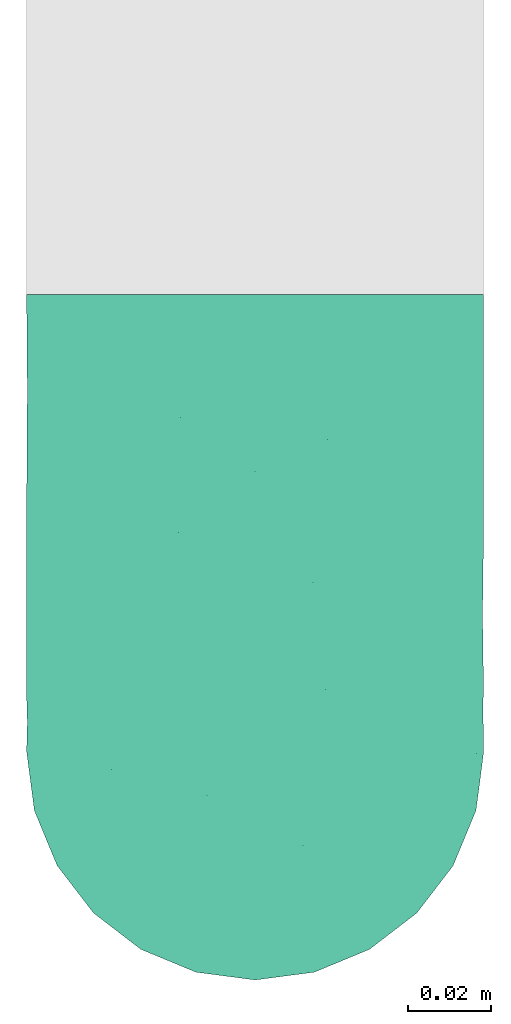
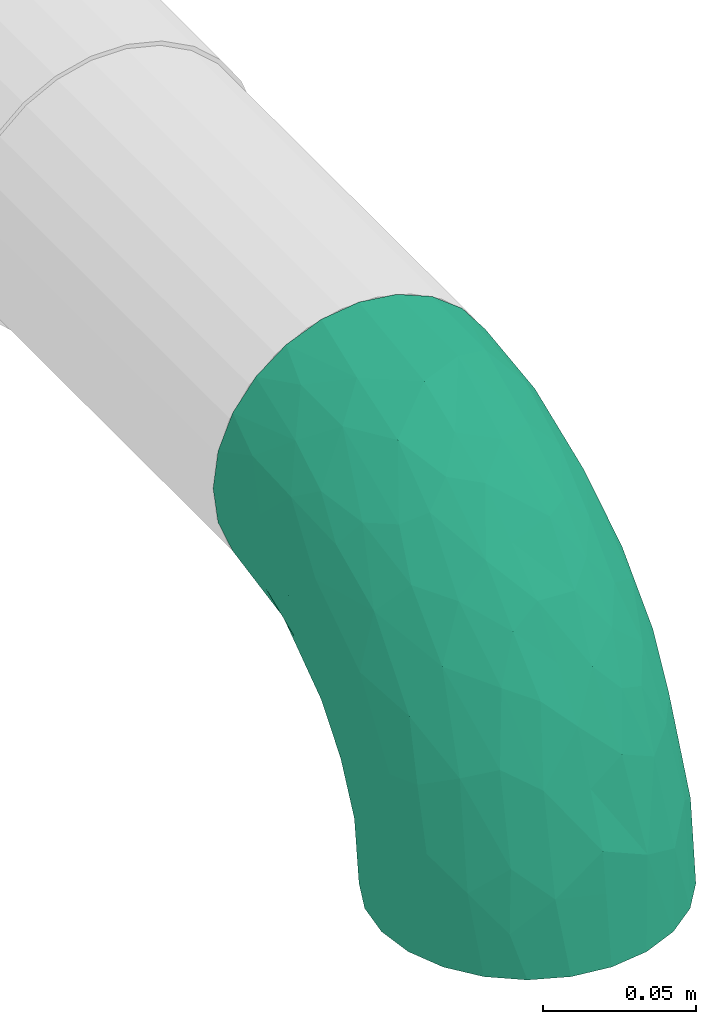
# One storey, part 2 of 2: 1 flow fitting.
"""IFC2X3 building model written with IfcOpenShell, lengths in millimetres."""

import ifcopenshell
import ifcopenshell.guid

model = None  # the IFC model being written
_history = None  # IfcOwnerHistory: only IFC2X3 demands one
_inside = {}  # id of a spatial element -> (the spatial element, [elements in it])
_under = {}  # id of a project, library or spatial element -> (it, [spatial elements below it])
_declared = {}  # id of a project -> (the project, [libraries it declares])
_typed = {}  # id of a type object -> (the type object, [elements of that type])
_made_of = {}  # id of a material, layer set ... -> (it, [elements and type objects made of it])


def new_model(schema):
    """Start an empty IFC model of exactly this schema.

    Asked for "IFC4X3", IfcOpenShell would pick the latest addendum, in which some entities
    have other attributes; the version numbers below select the first issue.
    IFC2X3 requires an IfcOwnerHistory on every rooted entity: one is made here for all.
    """
    global model, _history
    if schema == "IFC4X3":
        model = ifcopenshell.file(schema_version=(4, 3, 0, 0))
    else:
        model = ifcopenshell.file(schema=schema)
    _inside.clear()
    _under.clear()
    _declared.clear()
    _typed.clear()
    _made_of.clear()
    _history = None
    if model.schema == "IFC2X3":
        org = make("IfcOrganization", Name="unknown")
        user = make(
            "IfcPersonAndOrganization",
            ThePerson=make("IfcPerson", FamilyName="unknown"),
            TheOrganization=org,
        )
        app = make(
            "IfcApplication",
            ApplicationDeveloper=org,
            Version="unknown",
            ApplicationFullName="unknown",
            ApplicationIdentifier="unknown",
        )
        _history = make(
            "IfcOwnerHistory",
            OwningUser=user,
            OwningApplication=app,
            ChangeAction="ADDED",
            CreationDate=0,
        )
    return model


def make(cls, **values):
    """One entity of the class cls with the attributes given. An attribute that is None is left unset."""
    return model.create_entity(
        cls, **{name: value for name, value in values.items() if value is not None}
    )


def entity(cls, *values):
    """Any entity or typed value of the class cls, its attributes in the order of the schema. None: left unset."""
    e = model.create_entity(cls)
    for i, value in enumerate(values):
        if value is not None:
            e[i] = value
    return e


def rooted(cls, **values):
    """An entity with a GlobalId (a new one), such as an element, a storey or a relation."""
    return make(cls, GlobalId=ifcopenshell.guid.new(), OwnerHistory=_history, **values)


def si_unit(unit_type, name, prefix=None):
    """IfcSIUnit, for example si_unit("LENGTHUNIT", "METRE", prefix="MILLI")."""
    return make("IfcSIUnit", UnitType=unit_type, Prefix=prefix, Name=name)


def converted_unit(unit_type, name, factor, base, dimensions=None, offset=None):
    """IfcConversionBasedUnit, such as the inch: factor (a typed value) times the base unit."""
    return make(
        "IfcConversionBasedUnit"
        if offset is None
        else "IfcConversionBasedUnitWithOffset",
        ConversionOffset=offset,
        Dimensions=None
        if dimensions is None
        else entity("IfcDimensionalExponents", *dimensions),
        UnitType=unit_type,
        Name=name,
        ConversionFactor=make(
            "IfcMeasureWithUnit", ValueComponent=factor, UnitComponent=base
        ),
    )


def derived_unit(unit_type, elements):
    """IfcDerivedUnit: a product of units, each with its exponent."""
    return make(
        "IfcDerivedUnit",
        Elements=[
            make("IfcDerivedUnitElement", Unit=unit, Exponent=power)
            for unit, power in elements
        ],
        UnitType=unit_type,
    )


def assignment(units):
    """IfcUnitAssignment: the units of a project."""
    return None if units is None else make("IfcUnitAssignment", Units=units)


def point(xyz):
    """IfcCartesianPoint."""
    return None if xyz is None else make("IfcCartesianPoint", Coordinates=xyz)


def direction(xyz):
    """IfcDirection."""
    return None if xyz is None else make("IfcDirection", DirectionRatios=xyz)


def frame(location, z_axis=None, x_axis=None):
    """IfcAxis2Placement3D, a coordinate frame: its origin and axes. An axis left out is left unset."""
    return make(
        "IfcAxis2Placement3D",
        Location=point(location),
        Axis=direction(z_axis),
        RefDirection=direction(x_axis),
    )


def origin():
    """The frame at (0, 0, 0) with its axes left unset."""
    return frame((0.0, 0.0, 0.0))


def place(relative_to, where):
    """IfcLocalPlacement: puts the frame where relative to a parent placement (None: the world)."""
    return make(
        "IfcLocalPlacement", PlacementRelTo=relative_to, RelativePlacement=where
    )


def context(
    kind, dimensions, precision=None, world=None, true_north=None, identifier=None
):
    """IfcGeometricRepresentationContext, for example the 3D "Model" context."""
    return make(
        "IfcGeometricRepresentationContext",
        ContextIdentifier=identifier,
        ContextType=kind,
        CoordinateSpaceDimension=dimensions,
        Precision=precision,
        WorldCoordinateSystem=world,
        TrueNorth=true_north,
    )


def subcontext(parent, identifier, kind, view, scale=None):
    """IfcGeometricRepresentationSubContext, for example "Body" below "Model"."""
    return make(
        "IfcGeometricRepresentationSubContext",
        ContextIdentifier=identifier,
        ContextType=kind,
        ParentContext=parent,
        TargetScale=scale,
        TargetView=view,
    )


def project(units=None, contexts=None):
    """IfcProject with its units and contexts."""
    return rooted(
        "IfcProject",
        Name="project",
        RepresentationContexts=contexts,
        UnitsInContext=assignment(units),
    )


def spatial(cls, under=None, at=None, **own):
    """A site, building, storey or space (cls), placed at a placement, below another one or the project."""
    s = rooted(cls, ObjectPlacement=at, **own)
    if under is not None:
        _under.setdefault(under.id(), (under, []))[1].append(s)
    return s


def faces_of(points, faces, orient=None, outer=None):
    """IfcFace entities. A face is a list of loops; a loop is a list of indices into points, from 0.

    orient and outer hold one flag for each loop. By default every Orientation is true, the
    first loop of a face is its IfcFaceOuterBound and the others are IfcFaceBound.
    """
    made = []
    for i, loops in enumerate(faces):
        bounds = []
        for j, loop in enumerate(loops):
            is_outer = j == 0 if outer is None else outer[i][j]
            bounds.append(
                make(
                    "IfcFaceOuterBound" if is_outer else "IfcFaceBound",
                    Bound=make("IfcPolyLoop", Polygon=[points[k] for k in loop]),
                    Orientation=True if orient is None else orient[i][j],
                )
            )
        made.append(make("IfcFace", Bounds=bounds))
    return made


def faceted_brep(points, faces, orient=None, outer=None, voids=None):
    """IfcFacetedBrep: a solid bounded by flat faces; with voids (closed shells), ...WithVoids."""
    shared = [point(p) for p in points]
    hull = make("IfcClosedShell", CfsFaces=faces_of(shared, faces, orient, outer))
    if voids is None:
        return make("IfcFacetedBrep", Outer=hull)
    return make(
        "IfcFacetedBrepWithVoids",
        Outer=hull,
        Voids=[
            make(cls, CfsFaces=faces_of(shared, fs, o, b)) for cls, fs, o, b in voids
        ],
    )


def shape(context_of_items, identifier, shape_type, items):
    """IfcShapeRepresentation: the items that make up one representation, for example the "Body"."""
    return make(
        "IfcShapeRepresentation",
        ContextOfItems=context_of_items,
        RepresentationIdentifier=identifier,
        RepresentationType=shape_type,
        Items=items,
    )


def source(mapping_origin, context_of_items, identifier, shape_type, items):
    """IfcRepresentationMap: a shape defined once, which mapped items show again and again."""
    return make(
        "IfcRepresentationMap",
        MappingOrigin=mapping_origin,
        MappedRepresentation=shape(context_of_items, identifier, shape_type, items),
    )


def transform(
    local_origin,
    x_axis=None,
    y_axis=None,
    z_axis=None,
    scale=None,
    scale2=None,
    scale3=None,
    uniform=True,
):
    """IfcCartesianTransformationOperator3D, or its non-uniform kind. x_axis, y_axis, z_axis: its Axis1, 2, 3."""
    if uniform:
        return make(
            "IfcCartesianTransformationOperator3D",
            Axis1=direction(x_axis),
            Axis2=direction(y_axis),
            LocalOrigin=point(local_origin),
            Scale=scale,
            Axis3=direction(z_axis),
        )
    return make(
        "IfcCartesianTransformationOperator3DnonUniform",
        Axis1=direction(x_axis),
        Axis2=direction(y_axis),
        LocalOrigin=point(local_origin),
        Scale=scale,
        Axis3=direction(z_axis),
        Scale2=scale2,
        Scale3=scale3,
    )


def mapped(mapping_source, mapping_target):
    """IfcMappedItem: shows the shape of a source again, moved by a transform."""
    return make(
        "IfcMappedItem", MappingSource=mapping_source, MappingTarget=mapping_target
    )


def made_of(thing, what):
    """Note that an element or type object is made of a material, layer set ...; save() writes the relation."""
    if what is not None:
        _made_of.setdefault(what.id(), (what, []))[1].append(thing)
    return thing


def type_object(cls, material=None, **own):
    """A type object (cls), such as IfcWallType, which elements share."""
    return made_of(rooted(cls, **own), material)


def type_shapes(of_type, sources):
    """Give a type object the sources (RepresentationMaps) that its elements show as mapped items."""
    of_type.RepresentationMaps = sources


def element(
    cls,
    number,
    at=None,
    inside=None,
    cuts=None,
    type_object=None,
    material=None,
    context=None,
    identifier="Body",
    shape_type=None,
    held_by="IfcProductDefinitionShape",
    body=None,
    shapes=None,
    **own,
):
    """One element of the class cls, such as IfcWall. Its Tag is "e" and its number.

    at: its placement. inside: the storey or other place that contains it. cuts: it is an
    opening in that element (IfcRelVoidsElement). A single representation is given by context,
    identifier, shape_type and body (its items); several are given by shapes. held_by: the class
    of the entity that holds the representations. save() writes the other relations.
    """
    e = rooted(cls, Tag="e%d" % number, ObjectPlacement=at, **own)
    if body is not None:
        shapes = [shape(context, identifier, shape_type, body)]
    if shapes is not None:
        e.Representation = make(held_by, Representations=shapes)
    if inside is not None:
        _inside.setdefault(inside.id(), (inside, []))[1].append(e)
    if cuts is not None:
        rooted(
            "IfcRelVoidsElement", RelatingBuildingElement=cuts, RelatedOpeningElement=e
        )
    if type_object is not None:
        _typed.setdefault(type_object.id(), (type_object, []))[1].append(e)
    return made_of(e, material)


def aggregate(whole, parts):
    """IfcRelAggregates: a whole, such as a stair, and the parts it consists of."""
    return rooted("IfcRelAggregates", RelatingObject=whole, RelatedObjects=parts)


def save(model, path):
    """Write the relations noted so far, then the file.

    IfcRelAggregates (storeys below a building ...), IfcRelContainedInSpatialStructure (elements
    in a storey), IfcRelDefinesByType, IfcRelAssociatesMaterial and IfcRelDeclares: one each for
    every whole, place, type object, material and project.
    """
    for whole, parts in _under.values():
        aggregate(whole, parts)
    for where, things in _inside.values():
        rooted(
            "IfcRelContainedInSpatialStructure",
            RelatedElements=things,
            RelatingStructure=where,
        )
    for kind, things in _typed.values():
        rooted("IfcRelDefinesByType", RelatedObjects=things, RelatingType=kind)
    for what, things in _made_of.values():
        rooted("IfcRelAssociatesMaterial", RelatedObjects=things, RelatingMaterial=what)
    for by, libraries in _declared.values():
        rooted("IfcRelDeclares", RelatingContext=by, RelatedDefinitions=libraries)
    model.write(path)


model = new_model("IFC2X3")

# Units and contexts
model_context = context("Model", 3, precision=0.01, world=origin(), true_north=direction((6.12303176911189e-17, 1.0)))
body_context = subcontext(model_context, "Body", "Model", "MODEL_VIEW")
ifc_project = project(units=[si_unit("LENGTHUNIT", "METRE", prefix="MILLI"), si_unit("AREAUNIT", "SQUARE_METRE"), si_unit("VOLUMEUNIT", "CUBIC_METRE"), converted_unit("PLANEANGLEUNIT", "DEGREE", entity("IfcRatioMeasure", 0.0174532925199433), si_unit("PLANEANGLEUNIT", "RADIAN"), dimensions=[0, 0, 0, 0, 0, 0, 0]), si_unit("MASSUNIT", "GRAM", prefix="KILO"), derived_unit("MASSDENSITYUNIT", [(si_unit("MASSUNIT", "GRAM", prefix="KILO"), 1), (si_unit("LENGTHUNIT", "METRE"), -3)]), si_unit("TIMEUNIT", "SECOND"), si_unit("FREQUENCYUNIT", "HERTZ"), si_unit("THERMODYNAMICTEMPERATUREUNIT", "DEGREE_CELSIUS"), derived_unit("THERMALTRANSMITTANCEUNIT", [(si_unit("MASSUNIT", "GRAM", prefix="KILO"), 1), (si_unit("THERMODYNAMICTEMPERATUREUNIT", "KELVIN"), -1), (si_unit("TIMEUNIT", "SECOND"), -3)]), derived_unit("VOLUMETRICFLOWRATEUNIT", [(si_unit("LENGTHUNIT", "METRE"), 3), (si_unit("TIMEUNIT", "SECOND"), -1)]), si_unit("ELECTRICCURRENTUNIT", "AMPERE"), si_unit("ELECTRICVOLTAGEUNIT", "VOLT"), si_unit("POWERUNIT", "WATT"), si_unit("FORCEUNIT", "NEWTON", prefix="KILO"), si_unit("ILLUMINANCEUNIT", "LUX"), si_unit("LUMINOUSFLUXUNIT", "LUMEN"), si_unit("LUMINOUSINTENSITYUNIT", "CANDELA"), derived_unit("USERDEFINED", [(si_unit("MASSUNIT", "GRAM", prefix="KILO"), -1), (si_unit("LENGTHUNIT", "METRE"), -2), (si_unit("TIMEUNIT", "SECOND"), 3), (si_unit("LUMINOUSFLUXUNIT", "LUMEN"), 1)]), derived_unit("LINEARVELOCITYUNIT", [(si_unit("LENGTHUNIT", "METRE"), 1), (si_unit("TIMEUNIT", "SECOND"), -1)]), si_unit("PRESSUREUNIT", "PASCAL"), derived_unit("USERDEFINED", [(si_unit("LENGTHUNIT", "METRE"), -2), (si_unit("MASSUNIT", "GRAM", prefix="KILO"), 1), (si_unit("TIMEUNIT", "SECOND"), -2)])], contexts=[model_context])

# Site, building, storey
site_placement = place(None, origin())
site = spatial("IfcSite", under=ifc_project, at=site_placement, CompositionType="ELEMENT")
building_placement = place(site_placement, origin())
building = spatial("IfcBuilding", under=site, at=building_placement, CompositionType="ELEMENT")
storey_placement = place(building_placement, frame((0.0, 0.0, 16000.0)))
storey = spatial("IfcBuildingStorey", under=building, at=storey_placement, Name="04 Roof", CompositionType="ELEMENT", Elevation=16000.0)

# Flow fitting
pipe_fitting_type = type_object("IfcPipeFittingType", Name="pipe_fe_elbow_short_001", PredefinedType="NOTDEFINED")
shared_shape = source(origin(), body_context, "Body", "Brep", [
    faceted_brep([(-110.0, 27.5, -47.6313972081441), (-110.0, 14.2350474806387, -53.1259204458987), (-110.0, 0.0, -55.0), (-110.0, -14.2350474806386, -53.1259204458988), (-110.0, -27.4999999999999, -47.6313972081442), (-110.0, -38.89087296526, -38.8908729652602), (-110.0, -47.6313972081441, -27.5000000000001), (-110.0, -53.1259204458987, -14.2350474806388), (-110.0, -55.0, 0.0), (-110.0, -53.1259204458988, 14.2350474806385), (-110.0, -47.6313972081442, 27.4999999999998), (-110.0, -38.8908729652603, 38.89087296526), (-110.0, -27.5000000000002, 47.631397208144), (-110.0, -14.2350474806389, 53.1259204458987), (-110.0, 0.0, 55.0), (-110.0, 14.2350474806384, 53.1259204458988), (-110.0, 27.4999999999998, 47.6313972081443), (-110.0, 38.8908729652599, 38.8908729652603), (-110.0, 47.631397208144, 27.5000000000003), (-110.0, 53.1259204458987, 14.235047480639), (-110.0, 55.0, 0.0), (-110.0, 53.1259204458988, -14.2350474806386), (-110.0, 47.6313972081441, -27.5), (-110.0, 38.8908729652601, -38.8908729652601), (0.0, 110.0, -55.0), (-14.2350474806378, 110.0, -53.1259204458987), (-27.4999999999991, 110.0, -47.6313972081441), (-38.8908729652592, 110.0, -38.8908729652601), (-47.6313972081432, 110.0, -27.5), (-53.1259204458978, 110.0, -14.2350474806386), (-55.0, 110.0, 0.0), (-53.1259204458977, 110.0, 14.235047480639), (-47.631397208143, 110.0, 27.5000000000003), (-38.890872965259, 110.0, 38.8908729652603), (-27.4999999999988, 110.0, 47.6313972081443), (-14.2350474806374, 110.0, 53.1259204458988), (0.0, 110.0, 55.0), (14.2350474806398, 110.0, 53.1259204458987), (27.5000000000011, 110.0, 47.631397208144), (38.8908729652612, 110.0, 38.89087296526), (47.6313972081452, 110.0, 27.4999999999998), (53.1259204458998, 110.0, 14.2350474806385), (55.0, 110.0, 0.0), (53.1259204458997, 110.0, -14.2350474806388), (47.631397208145, 110.0, -27.5000000000001), (38.890872965261, 110.0, -38.8908729652602), (27.5000000000009, 110.0, -47.6313972081442), (14.2350474806395, 110.0, -53.1259204458988), (-80.8614667182396, -42.750870312251, 30.8912981726781), (-75.3019847106779, -48.4214770913905, 17.3948506906382), (-67.2948575580828, -49.3777613376962, 0.0), (-82.813061723732, -51.420771674175, 0.0), (25.9130349662994, 23.6720745101238, 20.561516655178), (22.8881259394888, 27.815573795585, 29.7673303440779), (12.9351326189179, 8.75494336923819, 24.4641672379252), (24.9116333592523, 44.7960208419035, 37.9156040877829), (13.2583654409811, 42.4754056344517, 45.7400856505813), (10.9130955140694, 20.239323769583, 37.1154641065968), (-80.781863855307, -20.7908972556475, 49.4802068955972), (-42.4754064694488, -13.2583656867661, 45.7400857745284), (-54.7576482176163, -0.49357045531903, 53.308930638976), (31.6831648206817, 71.9588756974551, 40.9636528549149), (-71.9588762431746, -31.6831649365399, 40.9636528814482), (-40.5614862597454, -37.7149262020745, 13.8716797713555), (-47.3974287790409, -41.1359764810642, 0.0), (-27.4999999999988, -32.8941916244322, 0.0), (-56.2043853600193, 95.1349584648676, 9.41382708018573), (-63.934325031754, 77.584979870886, 12.0106524628212), (-51.7962095379929, 95.4597395173479, 22.8965112952599), (-95.1572457660696, 33.3070564467507, 44.8153186314425), (-85.9778799102802, 45.8492394222781, 36.0947388555651), (-75.725945148771, 62.5607215129235, 19.3737522786357), (-67.1418593755357, 64.8694487444993, 27.272794982247), (-19.1150616797832, 54.086943711108, 54.9013192527886), (-40.7392931617093, 40.7392928785748, 53.6636170081982), (-32.7498005641182, 24.034545443042, 54.7166875706066), (-84.0223971114541, -7.28599883062967, 54.0593633346741), (-20.5305064367225, 94.8713617790666, 51.5173279005146), (-7.5379781678526, 82.272238680247, 54.8649100003475), (-77.0178545004283, 8.43075824290991, 54.9062543109624), (-79.9421015287995, 54.6881928755329, 28.4855249534227), (-92.09755559905, 54.24972248242, 19.4506219365676), (-3.88202937987992, -8.80040390128238, 24.3948227219531), (-0.302988573437923, 1.86290961978234, 32.9520523643338), (-18.8898164427893, -13.1192372273506, 34.0853692177653), (-95.6349905227676, 56.1102862697553, 9.17956807333299), (-78.1531639203173, 64.2274636210458, 9.12065010411484), (-14.8161277849932, -21.4876441151473, 16.9480019153111), (-21.5052012912214, -21.3592940578572, 26.1467372130245), (-71.1091270347389, 71.1091270347399, 0.0), (-88.952411219919, 59.1866257118793, 0.0), (-84.78290050373, 21.5707495793244, 51.9553730300389), (-14.3565401057912, 36.8375628342258, 54.0043728928146), (-27.3283789732182, 10.0898575069193, 51.3589175065086), (-5.61875033524846, 29.7149860929871, 50.5443326850198), (-9.82457195089315, 9.82457114972179, 44.9671654261315), (41.1359764810653, 47.3974287790422, 0.0), (37.7149264542136, 40.5614868018658, 13.8716797807438), (32.8941916244334, 27.5000000000001, 0.0), (42.7508701832419, 80.8614661519861, 30.8912982030535), (34.8005093769508, 47.9928031039947, 27.6946116064945), (48.4214767655532, 75.3019833809877, 17.3948507920336), (-47.9928042688795, -34.8005098849, 27.6946115921147), (7.28599886646176, 84.022397032146, 54.0593633249064), (-58.4713926840508, 37.3189353261603, 50.8717769026985), (-60.4381149385562, 23.559079906492, 54.0157373021661), (-53.9694695336828, 13.4773571856937, 54.9765288535067), (51.4207715841769, 82.8130610401217, 0.0), (-44.9538627087566, 70.4545718859753, 43.3290503548647), (-45.1876872823101, 88.6061044060773, 35.8064794794461), (-57.9756757995639, 61.423387665098, 38.9589934124074), (-23.7864831846653, 74.5263444063623, 52.3798088554537), (-59.1866257118783, 88.9524112199201, 0.0), (-34.7560326499963, 85.1821135810881, 45.5881627151598), (-41.6013180993071, 59.4561020796002, 49.0139698111169), (20.7908972323186, 80.7818634732262, 49.4802068662178), (-44.2327421799758, -24.9440342730778, 37.6244159383244), (49.3777613376972, 67.2948575580842, 0.0), (-58.7407898977324, 49.3535694987651, 45.7064305270436), (-75.7375025569545, 37.33495016788, 46.3156708970273), (-32.0384211652985, 57.0927388376619, 52.6873263742988), (0.493570496106845, 54.7576479797113, 53.3089306027056), (5.56804819519206, -4.98335760136098, 14.6065322830884), (-10.4136905521087, -19.7834052601062, 0.0), (6.67261889578144, -6.67261889578017, 0.0), (22.5914516399446, 13.8459067138997, 11.4884491706446), (-56.7681536779368, 77.8836119177664, 27.1528631978323), (19.7834052601074, 10.41369055211, 0.0), (-79.8504186193181, 36.0622914167174, -45.9987683659466), (-44.9323080964226, -13.8803703324461, -46.1437912879324), (-47.7588965812642, -0.686069795288819, -52.3114416952273), (-22.0982886652639, -0.920360663882017, -45.0667932146525), (-87.0692157381389, 6.9543948727856, -54.8209924063558), (-52.6485859545655, -41.2905966530194, -18.4972318172301), (-80.2365951766929, -49.2374841349802, -17.9304715433891), (-69.1060797929049, -40.7868437133216, -29.7899357137826), (-84.6306565287243, 21.5949873396476, -51.9618189354602), (-94.4068152162292, 56.3476806166975, -9.75688577159405), (-34.5211020224641, 86.3453484397506, -45.4984673684481), (-22.4514596039526, 80.0195122140998, -52.1549062326887), (-77.1806495361367, 63.6782662827213, -13.8400951600231), (18.9810714145825, 69.6520687919921, -48.9157166655639), (21.6826732392196, 92.8894018238158, -50.0562733821948), (32.8590890307617, 79.57064885983, -41.5258312491059), (-86.9601285573758, 45.5893856277908, -35.9868014215177), (-66.331363720321, 50.4016469023532, -41.4809329495405), (10.6402286726585, -0.763073473907959, -11.539491712069), (25.9982023784692, 18.2032276445382, -10.0191108836089), (-92.5976897181132, -43.7830753209609, -31.9551645376929), (-50.9380095305158, 63.9241053761659, -42.350886589947), (-50.8312755919223, 50.8312699098041, -48.2919358809824), (-27.7690767114023, -28.3422945650278, -20.7481614697685), (-3.42159364731061, -8.72673834015989, -23.8782843223197), (-7.64587629650911, -17.9500498455041, -11.1771158236218), (-79.5706492369985, -32.859089241441, -41.5258311383913), (-16.3850989276881, -11.0015535384037, -34.3087270401707), (4.41111089142905, 8.81241435710022, -34.6190997041592), (2.3153987706982, 25.8357830619315, -45.8674746415094), (22.4358767389364, 41.0658766847911, -38.4750534248012), (6.93482220339829, 81.0326029273676, -53.9943779063951), (49.2374840615515, 80.236595016723, -17.9304716674669), (-92.8894018343603, -21.682673360448, -50.0562733280801), (-41.0658761395333, -22.4358769413124, -38.4750529842642), (-31.4100773388878, -24.6461923541504, -30.2959991225043), (-60.0243949752165, -25.113297697785, -43.1850043760267), (-69.6520689974929, -18.9810717833319, -48.9157165161945), (-81.0326037172196, -6.93482257694107, -53.9943778729168), (-39.168057158188, 67.2528866629082, -47.7642324142595), (29.7556893882332, 37.1167060430164, -27.5221305254228), (40.7868435957884, 69.1060798947647, -29.7899359312135), (38.6006917534113, 44.047206618957, -16.1383717847835), (-59.1020532873347, 83.183215282615, -16.4904700296984), (-66.8366811534641, 65.3928874322993, -26.9787952362421), (0.686068845747843, 47.7588955873091, -52.3114418057823), (11.3674488683687, 46.9541254607366, -48.0478988363701), (-19.4163243794043, 19.4163232597233, -51.9347779792366), (-47.5797092845206, 80.508375737907, -36.7014680499595), (-51.6984307986878, 89.3717237094441, -26.5694587431122), (-6.9543951793164, 87.0692142779966, -54.820992407808), (43.7830752697207, 92.5976898422967, -31.95516462858), (-13.0018594488795, 60.5910626125726, -54.9881253370385), (-29.7400383447427, 32.0935635353313, -54.9687794214102), (-32.543824361366, 52.1399804747329, -53.3629807686834), (18.8423387792743, 13.4984503471383, -20.6534802405406), (-54.3027696403854, 31.8294113358122, -53.1839852433757), (-88.8159288162565, 53.4364683451642, -23.7670190169565), (-34.1432050242396, -35.2654629906484, -11.0480523503411), (-60.59106516761, 13.0018578374391, -54.9881253427786), (-61.3365551452822, 62.2905184046052, -35.6863830096526)], [[[0, 1, 2, 3, 4, 5, 6, 7, 8, 9, 10, 11, 12, 13, 14, 15, 16, 17, 18, 19, 20, 21, 22, 23]], [[24, 25, 26, 27, 28, 29, 30, 31, 32, 33, 34, 35, 36, 37, 38, 39, 40, 41, 42, 43, 44, 45, 46, 47]], [[48, 10, 49]], [[50, 49, 51]], [[52, 53, 54]], [[49, 10, 9]], [[9, 51, 49]], [[55, 56, 57]], [[11, 10, 48]], [[58, 59, 60]], [[61, 39, 38]], [[62, 12, 11]], [[62, 58, 12]], [[63, 64, 65]], [[66, 67, 68]], [[17, 69, 70]], [[67, 71, 72]], [[18, 17, 70]], [[73, 74, 75]], [[16, 69, 17]], [[13, 76, 14]], [[35, 77, 78]], [[14, 79, 15]], [[80, 81, 18]], [[82, 83, 84]], [[20, 19, 85]], [[71, 86, 85]], [[87, 82, 88]], [[89, 90, 86]], [[91, 15, 79]], [[15, 91, 16]], [[92, 93, 94]], [[95, 59, 84]], [[71, 85, 81]], [[96, 97, 98]], [[40, 39, 99]], [[100, 101, 99]], [[87, 88, 63]], [[48, 102, 62]], [[37, 36, 103]], [[104, 91, 105]], [[101, 41, 40]], [[31, 68, 32]], [[99, 101, 40]], [[105, 106, 75]], [[101, 107, 41]], [[49, 50, 64]], [[108, 109, 110]], [[111, 73, 78]], [[86, 67, 89]], [[14, 76, 79]], [[112, 66, 30]], [[34, 33, 113]], [[89, 67, 112]], [[80, 72, 71]], [[113, 111, 77]], [[114, 111, 113]], [[32, 68, 109]], [[115, 38, 37]], [[12, 58, 13]], [[61, 115, 56]], [[34, 77, 35]], [[36, 35, 78]], [[116, 59, 62]], [[66, 112, 67]], [[61, 38, 115]], [[101, 96, 117]], [[108, 118, 114]], [[118, 70, 119]], [[81, 80, 71]], [[109, 33, 32]], [[111, 114, 120]], [[111, 120, 73]], [[103, 78, 121]], [[59, 58, 62]], [[76, 58, 60]], [[116, 62, 102]], [[59, 95, 93]], [[103, 115, 37]], [[121, 94, 56]], [[121, 56, 115]], [[56, 95, 57]], [[105, 91, 79]], [[69, 91, 119]], [[102, 48, 49]], [[62, 11, 48]], [[39, 61, 99]], [[100, 99, 61]], [[122, 123, 124]], [[87, 122, 82]], [[87, 63, 65]], [[98, 97, 125]], [[122, 124, 125]], [[56, 55, 61]], [[85, 86, 90]], [[67, 86, 71]], [[20, 85, 90]], [[85, 19, 81]], [[19, 18, 81]], [[80, 18, 70]], [[70, 110, 80]], [[72, 110, 126]], [[113, 108, 114]], [[104, 118, 119]], [[105, 75, 74]], [[121, 78, 73]], [[93, 75, 60]], [[73, 75, 92]], [[78, 103, 36]], [[115, 103, 121]], [[58, 76, 13]], [[79, 76, 60]], [[110, 109, 126]], [[113, 33, 109]], [[105, 79, 106]], [[104, 105, 74]], [[114, 104, 74]], [[91, 104, 119]], [[114, 118, 104]], [[70, 118, 110]], [[79, 60, 106]], [[60, 75, 106]], [[110, 72, 80]], [[67, 72, 126]], [[83, 95, 84]], [[53, 57, 54]], [[53, 55, 57]], [[100, 61, 55]], [[59, 93, 60]], [[94, 93, 95]], [[56, 94, 95]], [[92, 94, 121]], [[73, 92, 121]], [[93, 92, 75]], [[68, 67, 126]], [[30, 66, 31]], [[9, 8, 51]], [[107, 101, 117]], [[107, 42, 41]], [[64, 63, 49]], [[49, 63, 102]], [[97, 101, 100]], [[101, 97, 96]], [[100, 53, 52]], [[122, 125, 54]], [[125, 124, 127, 98]], [[82, 122, 54]], [[87, 123, 122]], [[83, 54, 57]], [[88, 82, 84]], [[116, 88, 84]], [[63, 88, 102]], [[54, 83, 82]], [[95, 83, 57]], [[91, 69, 16]], [[70, 69, 119]], [[113, 77, 34]], [[78, 77, 111]], [[66, 68, 31]], [[109, 68, 126]], [[88, 116, 102]], [[84, 59, 116]], [[87, 65, 123]], [[114, 74, 120]], [[73, 120, 74]], [[109, 108, 113]], [[118, 108, 110]], [[54, 125, 52]], [[55, 53, 100]], [[125, 97, 52]], [[100, 52, 97]], [[23, 128, 0]], [[129, 130, 131]], [[2, 1, 132]], [[133, 134, 135]], [[0, 136, 1]], [[136, 0, 128]], [[90, 137, 20]], [[138, 26, 139]], [[90, 140, 137]], [[141, 142, 143]], [[144, 145, 128]], [[146, 147, 127]], [[25, 139, 26]], [[128, 23, 144]], [[134, 6, 148]], [[145, 149, 150]], [[134, 51, 7]], [[151, 152, 153]], [[154, 5, 4]], [[152, 155, 156]], [[156, 157, 158]], [[47, 159, 24]], [[160, 44, 43]], [[5, 148, 6]], [[4, 161, 154]], [[162, 163, 135]], [[135, 154, 164]], [[161, 4, 3]], [[165, 166, 130]], [[149, 167, 150]], [[89, 140, 90]], [[168, 169, 170]], [[171, 172, 140]], [[157, 173, 174]], [[29, 171, 30]], [[157, 175, 173]], [[166, 3, 2]], [[176, 177, 28]], [[172, 171, 177]], [[46, 45, 143]], [[24, 178, 25]], [[25, 178, 139]], [[179, 45, 44]], [[27, 26, 138]], [[28, 27, 176]], [[159, 47, 142]], [[161, 166, 165]], [[180, 181, 182]], [[171, 89, 112]], [[169, 160, 170]], [[152, 163, 155]], [[142, 47, 46]], [[143, 158, 141]], [[156, 168, 183]], [[160, 107, 117]], [[182, 139, 180]], [[184, 136, 128]], [[160, 169, 179]], [[6, 134, 7]], [[180, 159, 173]], [[144, 185, 172]], [[171, 112, 30]], [[149, 138, 167]], [[185, 21, 137]], [[153, 65, 186]], [[23, 22, 144]], [[179, 143, 45]], [[158, 143, 169]], [[173, 159, 141]], [[178, 159, 180]], [[174, 158, 157]], [[173, 175, 181]], [[160, 43, 107]], [[170, 117, 96, 98]], [[147, 170, 98]], [[168, 170, 183]], [[165, 129, 164]], [[148, 154, 135]], [[132, 166, 2]], [[187, 181, 130]], [[187, 130, 166]], [[130, 175, 131]], [[135, 163, 133]], [[43, 42, 107]], [[171, 140, 89]], [[177, 29, 28]], [[185, 22, 21]], [[128, 145, 150]], [[184, 128, 150]], [[132, 136, 187]], [[139, 182, 167]], [[176, 27, 138]], [[158, 168, 156]], [[131, 175, 157]], [[152, 156, 183]], [[156, 155, 131]], [[156, 131, 157]], [[131, 162, 129]], [[172, 185, 140]], [[144, 22, 185]], [[136, 132, 1]], [[166, 132, 187]], [[159, 178, 24]], [[139, 178, 180]], [[180, 173, 181]], [[184, 150, 182]], [[130, 181, 175]], [[184, 181, 187]], [[181, 184, 182]], [[136, 184, 187]], [[172, 188, 144]], [[188, 176, 149]], [[151, 186, 133]], [[64, 133, 186]], [[153, 146, 124]], [[155, 163, 162]], [[146, 152, 183]], [[153, 124, 123, 65]], [[188, 149, 145]], [[138, 149, 176]], [[139, 167, 138]], [[182, 150, 167]], [[144, 188, 145]], [[176, 188, 172]], [[163, 152, 151]], [[131, 155, 162]], [[152, 146, 153]], [[147, 146, 183]], [[170, 147, 183]], [[127, 124, 146]], [[147, 98, 127]], [[153, 186, 151]], [[64, 50, 133]], [[186, 65, 64]], [[50, 134, 133]], [[163, 151, 133]], [[51, 134, 50]], [[51, 8, 7]], [[185, 137, 140]], [[20, 137, 21]], [[143, 142, 46]], [[159, 142, 141]], [[160, 179, 44]], [[143, 179, 169]], [[166, 161, 3]], [[154, 161, 165]], [[154, 148, 5]], [[134, 148, 135]], [[117, 170, 160]], [[169, 168, 158]], [[172, 177, 176]], [[29, 177, 171]], [[173, 141, 174]], [[158, 174, 141]], [[164, 129, 162]], [[130, 129, 165]], [[135, 164, 162]], [[165, 164, 154]]]),
])
type_shapes(pipe_fitting_type, [shared_shape])
flow_fitting_placement = place(storey_placement, frame((30839.7885390445, -68160.8241905963, 1000.0), z_axis=(1.0, 0.0, 0.0), x_axis=(0.0, -1.0, 0.0)))
element("IfcFlowFitting", 1, at=flow_fitting_placement, inside=storey, type_object=pipe_fitting_type, Name="pipe_fe_elbow_short_001:pipe_fe_elbow_short_001", ObjectType="pipe_fe_elbow_short_001:pipe_fe_elbow_short_001", context=body_context, shape_type="MappedRepresentation", body=[
    mapped(shared_shape, transform((0.0, 0.0, 0.0), scale=1.0)),
])

save(model, "model.ifc")
